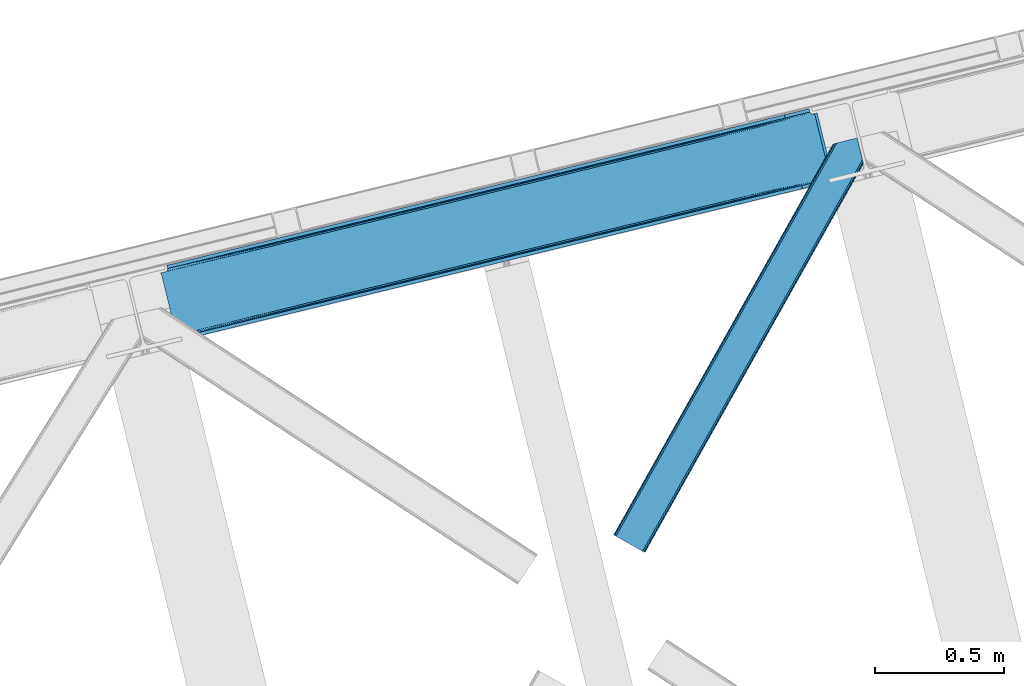
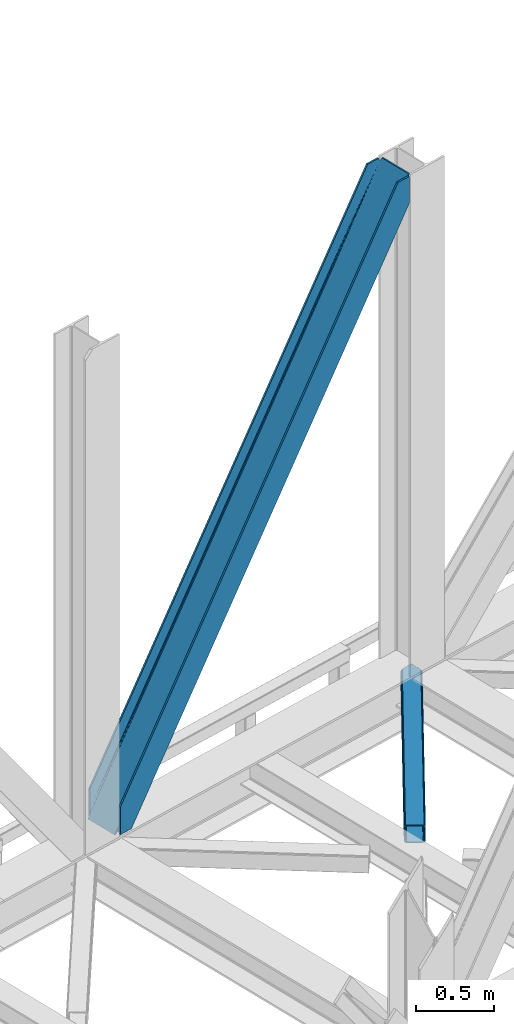
# One storey, part 77 of 93: 2 members.
"""IFC4 building model written with IfcOpenShell, lengths in millimetres."""

from ifc_helpers import new_model, entity, si_unit, converted_unit, derived_unit, direction, frame, origin, place, context, subcontext, project, spatial, triangles, type_object, element, save


model = new_model("IFC4")

# Units and contexts
model_context = context("Model", 3, precision=0.01, world=origin(), true_north=direction((6.12303176911189e-17, 1.0)))
plan_context = context("Plan", 3, precision=0.01, world=origin(), true_north=direction((6.12303176911189e-17, 1.0)))
body_context = subcontext(model_context, "Body", "Model", "MODEL_VIEW")
ifc_project = project(units=[si_unit("LENGTHUNIT", "METRE", prefix="MILLI"), si_unit("AREAUNIT", "SQUARE_METRE"), si_unit("VOLUMEUNIT", "CUBIC_METRE"), converted_unit("PLANEANGLEUNIT", "DEGREE", entity("IfcRatioMeasure", 0.0174532925199433), si_unit("PLANEANGLEUNIT", "RADIAN"), dimensions=[0, 0, 0, 0, 0, 0, 0]), si_unit("MASSUNIT", "GRAM", prefix="KILO"), derived_unit("MASSDENSITYUNIT", [(si_unit("MASSUNIT", "GRAM", prefix="KILO"), 1), (si_unit("LENGTHUNIT", "METRE"), -3)]), derived_unit("MOMENTOFINERTIAUNIT", [(si_unit("LENGTHUNIT", "METRE"), 4)]), si_unit("TIMEUNIT", "SECOND"), si_unit("FREQUENCYUNIT", "HERTZ"), si_unit("THERMODYNAMICTEMPERATUREUNIT", "DEGREE_CELSIUS"), derived_unit("THERMALTRANSMITTANCEUNIT", [(si_unit("MASSUNIT", "GRAM", prefix="KILO"), 1), (si_unit("THERMODYNAMICTEMPERATUREUNIT", "KELVIN"), -1), (si_unit("TIMEUNIT", "SECOND"), -3)]), derived_unit("VOLUMETRICFLOWRATEUNIT", [(si_unit("LENGTHUNIT", "METRE"), 3), (si_unit("TIMEUNIT", "SECOND"), -1)]), derived_unit("MASSFLOWRATEUNIT", [(si_unit("MASSUNIT", "GRAM", prefix="KILO"), 1), (si_unit("TIMEUNIT", "SECOND"), -1)]), derived_unit("ROTATIONALFREQUENCYUNIT", [(si_unit("TIMEUNIT", "SECOND"), -1)]), si_unit("ELECTRICCURRENTUNIT", "AMPERE"), si_unit("ELECTRICVOLTAGEUNIT", "VOLT"), si_unit("POWERUNIT", "WATT"), si_unit("FORCEUNIT", "NEWTON", prefix="KILO"), si_unit("ILLUMINANCEUNIT", "LUX"), si_unit("LUMINOUSFLUXUNIT", "LUMEN"), si_unit("LUMINOUSINTENSITYUNIT", "CANDELA"), derived_unit("USERDEFINED", [(si_unit("MASSUNIT", "GRAM", prefix="KILO"), -1), (si_unit("LENGTHUNIT", "METRE"), -2), (si_unit("TIMEUNIT", "SECOND"), 3), (si_unit("LUMINOUSFLUXUNIT", "LUMEN"), 1)]), derived_unit("LINEARVELOCITYUNIT", [(si_unit("LENGTHUNIT", "METRE"), 1), (si_unit("TIMEUNIT", "SECOND"), -1)]), si_unit("PRESSUREUNIT", "PASCAL"), derived_unit("USERDEFINED", [(si_unit("LENGTHUNIT", "METRE"), -2), (si_unit("MASSUNIT", "GRAM", prefix="KILO"), 1), (si_unit("TIMEUNIT", "SECOND"), -2)]), derived_unit("LINEARFORCEUNIT", [(si_unit("MASSUNIT", "GRAM", prefix="KILO"), 1), (si_unit("LENGTHUNIT", "METRE"), 1), (si_unit("TIMEUNIT", "SECOND"), -2), (si_unit("LENGTHUNIT", "METRE"), -1)]), derived_unit("PLANARFORCEUNIT", [(si_unit("MASSUNIT", "GRAM", prefix="KILO"), 1), (si_unit("LENGTHUNIT", "METRE"), 1), (si_unit("TIMEUNIT", "SECOND"), -2), (si_unit("LENGTHUNIT", "METRE"), -2)])], contexts=[model_context, plan_context])

# Site, building, storey
site_placement = place(None, origin())
site = spatial("IfcSite", under=ifc_project, at=site_placement, CompositionType="ELEMENT")
building_placement = place(site_placement, origin())
building = spatial("IfcBuilding", under=site, at=building_placement, CompositionType="ELEMENT")
storey_placement = place(building_placement, frame((0.0, 0.0, 15900.0)))
storey = spatial("IfcBuildingStorey", under=building, at=storey_placement, CompositionType="ELEMENT", Elevation=15900.0)

# Members
member_type_1 = type_object("IfcMemberType", PredefinedType="BRACE")
member_1_placement = place(storey_placement, frame((-11645.7647369385, 17824.6027038574, 3694.99929199219)))
element("IfcMember", 1, at=member_1_placement, inside=storey, type_object=member_type_1, ObjectType="Steel Vertical Brace", PredefinedType="BRACE", context=body_context, shape_type="Tessellation", body=[
    triangles([(2543.71740875244, 876.026760864261, 3910.2403930664), (2543.86100463867, 877.205758666994, 3909.96134033203), (2542.34249267578, 876.834851074222, 3911.00081176758), (2544.23714447021, 869.063232421875, 3911.00081176758), (2527.1870223999, 873.140890502931, 3906.29412231445), (2530.23276672363, 873.882705688477, 3911.00081176758), (2527.1870223999, 873.140890502931, 3884.1908203125), (2518.86892547608, 874.429183959961, 3898.31321411133), (2521.01472473145, 873.423431396484, 3899.16199951172), (2522.8994934082, 872.957180786136, 3877.06799926758), (2518.86892547608, 874.429183959961, 3868.81036376953), (2517.28820800781, 875.594229125978, 3898.850390625), (2517.28820800781, 875.594229125978, 3864.49202270508), (2515.87201538086, 877.455743408205, 3857.29478759765), (2515.70574645996, 877.331332397462, 3901.61533813476), (2513.89597320557, 881.222955322268, 3911.00081176758), (2514.70987701416, 878.98239440918, 3851.39514770508), (2514.17793273926, 880.262548828126, 3838.64708862305), (2514.70987701416, 878.98239440918, 3906.82664794922), (2514.37326965332, 879.734674072268, 3911.00081176758), (2514.17793273926, 880.262548828126, 3698.36960449219), (2513.89597320557, 881.222955322268, 3698.30216674805), (2522.8994934082, 872.957180786136, 3900.77120361328), (1281.82757263184, 579.864605712894, 1933.79126586914), (121.508862304689, 297.023730468751, 0.0), (1706.06330566406, 683.275735473635, 2589.5349609375), (2130.29787597656, 786.688027954104, 3245.28098144531), (857.58835144043, 476.451150512698, 1278.04757080078), (30.7527740478527, 274.901824951172, 0.0), (433.353781127931, 373.040020751956, 622.301550292967), (2511.05370483398, 892.881546020508, 3698.30216674805), (118.429980468751, 309.654354858401, 0.0), (2511.05370483398, 892.881546020508, 3911.00081176758), (2415.21013641357, 869.519018554689, 3911.00081176758), (23.883425903321, 286.608087158205, 214.700848388671), (23.883425903321, 286.608087158205, 0.0), (26.9576568603516, 273.658877563477, 0.0), (26.7251129150391, 274.948333740234, 0.0), (26.7251129150391, 274.948333740234, 214.700848388671), (2509.04452514648, 879.011462402344, 3911.00081176758), (2418.28901824951, 856.888394165042, 3911.00081176758), (26.9169616699219, 273.965835571289, 214.633410644528), (1250.04927978516, 572.117404174805, 1964.95680541992), (1676.92671203613, 676.173843383789, 2624.78862304687), (2103.8058883667, 780.230282592776, 3284.61811523437), (823.166033935548, 468.060964965822, 1305.12731323242), (26.9169616699219, 273.965835571289, 74.3536010742173), (396.287438964844, 364.004525756838, 645.295495605467), (25.435656738282, 266.62907409668, 14.6874755859353), (23.9973724365245, 264.751281738281, 13.8410156249993), (22.5346710205085, 263.467639160157, 35.9326904296868), (25.435656738282, 266.62907409668, 44.192651367186), (26.2995574951183, 268.389431762698, 14.1502990722656), (26.0007385253921, 268.181304931641, 48.2249633789033), (26.9088226318363, 270.661386108401, 54.6571289062485), (26.9088226318363, 270.661386108401, 11.3853515624978), (27.0332336425781, 272.584524536134, 61.6055419921868), (27.0332336425781, 272.584524536134, 6.17404174804688), (22.5346710205085, 263.467639160157, 12.2294860839829), (18.6395599365242, 261.656121826174, 28.8121948242188), (18.6395599365242, 261.656121826174, 6.70889282226563), (0.0, 257.112213134766, 0.0), (14.3014526367188, 260.598046875002, 0.0), (412.366690063478, 356.486380004884, 636.079779052732), (0.597637939454216, 256.057626342776, 0.0), (4.08579711914172, 249.874282836914, 0.0), (2122.62276306152, 766.289273071292, 3274.64197998047), (2534.31914520264, 866.644775390625, 3911.00081176758), (2530.82982330322, 872.828118896487, 3911.00081176758), (2119.88455810547, 772.712136840823, 3275.40239868164), (2109.70145874024, 780.257025146486, 3280.80206909179), (2115.34762573242, 777.616488647462, 3277.56505737305), (407.82975769043, 361.391894531251, 638.242437744138), (402.183590698243, 364.031268310548, 641.479449462888), (415.109545898438, 350.064678955081, 635.319360351561), (829.062185668947, 468.087707519531, 1301.30894165039), (1255.93961791992, 572.142984008791, 1961.14075927734), (1682.81821289063, 676.199423217775, 2620.97025146484), (834.707189941408, 465.447171020511, 1298.07192993164), (1261.58578491211, 569.503610229494, 1957.90374755859), (1688.46903076172, 673.561212158205, 2617.73323974609), (839.24877319336, 460.543981933595, 1295.90927124023), (1266.12736816406, 564.600421142579, 1955.74108886719), (1693.00596313477, 668.656860351563, 2615.57058105469), (841.988140869142, 454.121118164065, 1295.15117797851), (1268.86557312012, 558.177557373048, 1954.98067016601), (1695.74416809082, 662.233996582032, 2614.81248779297), (428.11107788086, 370.350650024415, 626.119921874997), (424.31247253418, 365.409091186524, 629.35693359375), (2119.48225708008, 772.614468383792, 3254.49669799805), (2121.25307922363, 779.057098388672, 3252.33403930664), (423.061386108398, 352.004095458986, 632.280010986327), (14.0096099853527, 252.292739868164, 0.0), (14.2619201660164, 259.388818359377, 0.0), (422.53699951172, 358.966461181641, 631.519592285156), (2125.05110321045, 783.998657226563, 3249.09702758789), (846.772732543946, 462.377590942386, 1287.26328735351), (847.297119140625, 455.415225219727, 1288.02370605469), (1271.00730285645, 565.789883422854, 1943.00930786133), (1271.53168945313, 558.827517700196, 1943.76740112304), (1695.24303588867, 669.201013183596, 2598.75300292969), (1695.76742248535, 662.238647460938, 2599.5110961914), (2120.00199279785, 765.650939941406, 3255.25711669922), (848.548205566407, 468.821383666993, 1285.10062866211), (1272.78277587891, 572.232513427734, 1940.84664916992), (1697.01850891113, 675.644805908203, 2596.59034423828), (852.345648193361, 473.762942504884, 1281.86361694336), (1276.58138122559, 577.175234985352, 1937.60963745117), (1700.81595153809, 680.586364746094, 2593.35333251953), (2589.49949798584, 640.273709106448, 3911.00081176758), (2177.80311584473, 539.918206787112, 3274.64197998047), (1324.04592590332, 331.805328369141, 1954.98067016601), (1750.92452087402, 435.861767578128, 2614.81248779297), (897.168493652345, 227.750051879884, 1295.15117797851), (470.289898681642, 123.693612670901, 635.319360351561), (59.2673126220707, 23.50205383301, 0.0), (2599.41749725342, 642.691003417971, 3911.00081176758), (2175.18234558106, 539.278710937502, 3255.25711669922), (1750.94777526856, 435.867581176761, 2599.5110961914), (1326.71204223633, 332.455288696292, 1943.76740112304), (902.477471923828, 229.044158935547, 1288.02370605469), (478.241738891602, 125.631866455078, 632.280010986327), (69.1899627685561, 25.9216735839873, 0.0), (59.015002441407, 16.4071380615242, 0.0), (72.6781219482436, 19.7383300781257, 0.0), (58.9696563720718, 15.1955841064482, 0.0), (73.2711090087905, 18.6825805664084, 0.0), (77.6092163085941, 19.739492797853, 6.70889282226563), (77.6092163085941, 19.739492797853, 28.8121948242188), (2589.24718780518, 633.177630615235, 3911.00081176758), (2601.31214904785, 634.918222045901, 3911.00081176758), (2589.2024230957, 631.967239379883, 3911.00081176758), (2602.83066101074, 635.289129638673, 3909.96134033203), (2602.16035308838, 636.269302368164, 3910.2403930664), (2586.15667877197, 631.22426147461, 3906.29412231445), (2586.15667877197, 631.22426147461, 3884.1908203125), (2572.75110168457, 617.663461303713, 3911.00081176758), (2577.81474609375, 619.473815917969, 3911.00081176758), (2577.76765594482, 620.297021484377, 3906.82664794922), (2172.75865631104, 521.571652221683, 3280.80206909179), (2577.89206695557, 622.220159912111, 3901.61533813476), (2578.49726257324, 624.490951538086, 3898.850390625), (2582.2662185669, 629.413906860354, 3900.77120361328), (2178.32750244141, 532.955841064453, 3275.40239868164), (2580.80293579102, 628.130264282227, 3899.15967407226), (2579.36465148926, 626.252471923828, 3898.31321411133), (2176.55668029785, 526.513211059573, 3277.56505737305), (470.809634399415, 116.730084228519, 636.079779052732), (469.03881225586, 110.288616943362, 638.242437744138), (81.900814819337, 19.9232025146484, 35.9326904296868), (85.9319641113289, 18.4523620605469, 44.192651367186), (87.5086120605483, 17.2861541748061, 48.5109924316384), (2167.51188354492, 518.882281494141, 3284.61811523437), (459.994015502931, 102.656524658203, 645.295495605467), (465.24020690918, 105.345895385744, 641.479449462888), (90.6235382080085, 12.618997192385, 74.3536010742173), (90.0910125732426, 13.899151611331, 61.6055419921868), (88.9282928466801, 15.4258026123061, 55.7059020996094), (897.692880249024, 220.787686157229, 1295.90927124023), (1324.5703125, 324.844125366213, 1955.74108886719), (1751.4489074707, 428.899401855469, 2615.57058105469), (895.916244506836, 214.343893432619, 1298.07192993164), (1322.79483947754, 318.400332641602, 1957.90374755859), (1749.67808532715, 422.457934570313, 2617.73323974609), (892.118801879884, 209.402334594728, 1301.30894165039), (1318.99739685059, 313.458773803712, 1961.14075927734), (1745.87599182129, 417.514050292972, 2620.97025146484), (886.872610473634, 206.71296386719, 1305.12731323242), (1313.75469360352, 310.770565795901, 1964.95680541992), (1740.63328857422, 414.827005004885, 2624.78862304687), (90.6235382080085, 12.618997192385, 214.633410644528), (2481.9955947876, 595.541555786134, 3911.00081176758), (491.167694091797, 111.666439819339, 626.119921874997), (89.0945617675789, 15.5502136230498, 11.3853515624978), (87.5086120605483, 17.2861541748061, 14.1502990722656), (90.0910125732426, 13.899151611331, 6.17404174804688), (480.981106567384, 119.210165405275, 631.519592285156), (83.7855834960938, 19.4581146240234, 13.8386901855447), (81.900814819337, 19.9232025146484, 12.2294860839829), (85.9319641113289, 18.4523620605469, 14.6874755859353), (485.52152709961, 114.305813598636, 629.35693359375), (2182.46213378906, 527.953820800783, 3252.33403930664), (2582.2662185669, 629.413906860354, 3877.06799926758), (2579.36465148926, 626.252471923828, 3868.81036376953), (2177.92520141602, 532.858172607423, 3254.49669799805), (2578.79608154297, 624.697915649416, 3864.77572631836), (2577.89206695557, 622.220159912111, 3858.34588623047), (2188.10830078125, 525.313284301759, 3249.09702758789), (2577.76765594482, 620.297021484377, 3851.39514770508), (94.4593505859375, 13.5538238525405, 0.0), (90.5188934326179, 12.9108398437529, 0.0), (497.059194946291, 111.692019653321, 622.301550292967), (2577.88392791748, 618.914547729495, 3838.64708862305), (2194.00445251465, 525.340026855469, 3245.28098144531), (915.403427124023, 215.07756958008, 1281.86361694336), (921.294927978517, 215.10431213379, 1278.04757080078), (1339.63799743652, 318.489862060549, 1937.60963745117), (1345.53414916992, 318.516604614259, 1933.79126586914), (1763.87373046875, 421.900991821291, 2593.35333251953), (1769.76871948242, 421.928897094727, 2589.5349609375), (909.757260131837, 217.718106079104, 1285.10062866211), (1333.99183044434, 321.129235839846, 1940.84664916992), (1758.22756347656, 424.541528320315, 2596.59034423828), (905.215676879883, 222.621295166016, 1287.26328735351), (1329.45024719238, 326.033587646485, 1943.00930786133), (1753.68598022461, 429.444717407227, 2598.75300292969), (90.9049163818363, 11.6585906982436, 0.0), (90.9049163818363, 11.6585906982436, 214.700848388671), (2485.07389526367, 582.910931396487, 3911.00081176758), (93.7466033935561, 0.0, 214.700848388671), (93.7466033935561, 0.0, 0.0), (188.293157958986, 23.046267700196, 0.0), (185.214276123048, 35.6768920898467, 0.0), (2577.88392791748, 618.914547729495, 3698.36960449219), (2578.07577667236, 617.93204956055, 3911.00081176758), (2578.07577667236, 617.93204956055, 3698.30216674805), (2580.91746368408, 606.273458862306, 3698.30216674805), (2580.91746368408, 606.273458862306, 3911.00081176758)], [[1, 2, 3], [3, 4, 1], [3, 5, 6], [5, 3, 2], [7, 5, 2], [8, 9, 10], [10, 11, 8], [8, 11, 12], [13, 12, 11], [14, 15, 12], [16, 17, 18], [19, 15, 14], [16, 20, 19], [19, 17, 16], [14, 17, 19], [18, 21, 22], [22, 16, 18], [13, 14, 12], [9, 23, 10], [5, 7, 23], [10, 23, 7], [21, 24, 25], [26, 21, 27], [21, 26, 24], [21, 18, 27], [28, 25, 24], [29, 25, 30], [28, 30, 25], [31, 22, 32], [22, 21, 25], [25, 32, 22], [16, 22, 33], [31, 33, 22], [34, 31, 35], [31, 34, 33], [32, 35, 31], [36, 35, 32], [32, 29, 36], [29, 32, 25], [37, 38, 29], [38, 36, 29], [38, 39, 35], [35, 36, 38], [16, 33, 40], [20, 16, 40], [34, 40, 33], [34, 41, 40], [39, 34, 35], [41, 39, 42], [39, 41, 34], [41, 42, 43], [43, 44, 41], [44, 45, 41], [40, 41, 45], [46, 43, 42], [42, 47, 48], [48, 46, 42], [49, 50, 51], [51, 52, 49], [53, 49, 52], [52, 54, 53], [55, 56, 53], [57, 58, 55], [56, 55, 58], [38, 37, 58], [58, 47, 38], [39, 38, 47], [47, 42, 39], [57, 47, 58], [54, 55, 53], [50, 59, 51], [51, 59, 60], [61, 60, 59], [60, 61, 62], [63, 62, 61], [64, 65, 66], [67, 68, 69], [70, 8, 12], [70, 69, 23], [23, 9, 70], [9, 8, 70], [69, 5, 23], [69, 6, 5], [71, 72, 12], [12, 15, 71], [19, 40, 45], [45, 71, 19], [73, 74, 57], [57, 55, 73], [64, 51, 60], [60, 65, 64], [60, 62, 65], [64, 73, 54], [54, 52, 64], [52, 51, 64], [55, 54, 73], [74, 48, 47], [47, 57, 74], [19, 20, 40], [15, 19, 71], [12, 72, 70], [69, 70, 67], [66, 75, 64], [76, 46, 48], [48, 74, 76], [77, 43, 46], [46, 76, 77], [78, 44, 43], [43, 77, 78], [71, 45, 78], [44, 78, 45], [79, 76, 73], [74, 73, 76], [80, 77, 79], [76, 79, 77], [81, 78, 80], [77, 80, 78], [72, 71, 78], [78, 81, 72], [82, 79, 64], [73, 64, 79], [83, 80, 79], [79, 82, 83], [84, 81, 80], [80, 83, 84], [70, 72, 81], [81, 84, 70], [85, 82, 64], [64, 75, 85], [86, 83, 82], [82, 85, 86], [87, 84, 86], [83, 86, 84], [67, 70, 87], [84, 87, 70], [88, 89, 53], [53, 56, 88], [30, 88, 58], [58, 29, 30], [90, 10, 7], [7, 1, 90], [7, 2, 1], [90, 91, 13], [13, 11, 90], [11, 10, 90], [92, 93, 94], [95, 49, 53], [95, 94, 61], [61, 59, 95], [59, 50, 95], [50, 49, 95], [94, 63, 61], [53, 89, 95], [94, 95, 92], [14, 91, 17], [14, 13, 91], [91, 96, 17], [18, 17, 96], [96, 27, 18], [58, 37, 29], [56, 58, 88], [97, 98, 92], [92, 95, 97], [99, 100, 98], [98, 97, 99], [101, 102, 100], [100, 99, 101], [90, 103, 102], [102, 101, 90], [1, 4, 90], [103, 90, 4], [104, 97, 95], [95, 89, 104], [105, 99, 104], [97, 104, 99], [106, 101, 105], [99, 105, 101], [91, 90, 101], [101, 106, 91], [107, 104, 88], [89, 88, 104], [108, 105, 107], [104, 107, 105], [109, 106, 105], [105, 108, 109], [96, 91, 106], [106, 109, 96], [28, 107, 88], [88, 30, 28], [24, 108, 107], [107, 28, 24], [26, 109, 24], [108, 24, 109], [27, 96, 26], [109, 26, 96], [110, 68, 67], [87, 111, 67], [112, 113, 87], [112, 87, 86], [67, 111, 110], [87, 113, 111], [85, 114, 112], [112, 86, 85], [85, 75, 115], [66, 116, 75], [85, 115, 114], [75, 116, 115], [4, 117, 118], [119, 103, 118], [100, 102, 119], [100, 119, 120], [118, 103, 4], [119, 102, 103], [98, 100, 120], [120, 121, 98], [121, 122, 92], [123, 93, 122], [121, 92, 98], [122, 93, 92], [66, 116, 93], [116, 124, 125], [124, 126, 125], [62, 65, 63], [65, 66, 94], [93, 116, 123], [127, 125, 126], [125, 123, 116], [93, 94, 66], [94, 63, 65], [128, 129, 126], [126, 127, 128], [110, 130, 131], [130, 132, 131], [6, 69, 3], [3, 69, 68], [110, 117, 68], [68, 117, 4], [110, 131, 117], [4, 3, 68], [133, 134, 131], [117, 131, 134], [131, 135, 133], [131, 132, 135], [135, 136, 133], [137, 138, 139], [140, 141, 142], [140, 139, 141], [130, 143, 135], [144, 145, 143], [144, 146, 145], [143, 130, 144], [135, 132, 130], [144, 147, 142], [142, 146, 144], [111, 144, 130], [148, 115, 116], [149, 150, 151], [148, 124, 129], [129, 149, 148], [129, 150, 149], [124, 126, 129], [151, 152, 149], [116, 124, 148], [130, 110, 111], [142, 147, 140], [137, 139, 153], [140, 153, 139], [154, 155, 156], [157, 156, 155], [157, 149, 158], [157, 155, 149], [152, 158, 149], [159, 114, 148], [115, 148, 114], [160, 112, 159], [114, 159, 112], [161, 113, 112], [112, 160, 161], [144, 111, 113], [113, 161, 144], [162, 159, 148], [148, 149, 162], [163, 160, 162], [159, 162, 160], [164, 161, 163], [160, 163, 161], [147, 144, 164], [161, 164, 144], [165, 162, 149], [149, 155, 165], [166, 163, 162], [162, 165, 166], [167, 164, 163], [163, 166, 167], [140, 147, 167], [164, 167, 147], [168, 165, 154], [155, 154, 165], [169, 166, 168], [165, 168, 166], [170, 167, 169], [166, 169, 167], [153, 140, 167], [167, 170, 153], [169, 171, 172], [172, 153, 170], [153, 172, 137], [170, 169, 172], [171, 169, 168], [168, 154, 171], [156, 171, 154], [173, 174, 175], [173, 176, 174], [177, 178, 179], [177, 180, 178], [179, 128, 177], [128, 125, 177], [128, 127, 125], [177, 181, 175], [175, 180, 177], [122, 177, 125], [182, 183, 184], [185, 134, 136], [136, 182, 185], [136, 183, 182], [134, 133, 136], [184, 186, 182], [182, 186, 187], [187, 188, 182], [187, 189, 188], [190, 191, 176], [173, 192, 176], [190, 176, 192], [189, 193, 188], [194, 188, 193], [125, 123, 122], [175, 181, 173], [195, 196, 173], [192, 173, 196], [197, 198, 195], [196, 195, 198], [199, 200, 198], [198, 197, 199], [188, 194, 200], [200, 199, 188], [201, 195, 173], [173, 181, 201], [202, 197, 195], [195, 201, 202], [203, 199, 197], [197, 202, 203], [182, 188, 199], [199, 203, 182], [204, 201, 177], [181, 177, 201], [205, 202, 201], [201, 204, 205], [206, 203, 205], [202, 205, 203], [185, 182, 206], [203, 206, 182], [121, 204, 122], [177, 122, 204], [120, 205, 121], [204, 121, 205], [119, 206, 205], [205, 120, 119], [118, 185, 206], [206, 119, 118], [117, 134, 185], [185, 118, 117], [180, 151, 150], [150, 179, 178], [175, 158, 152], [175, 152, 151], [151, 180, 175], [207, 157, 176], [176, 157, 158], [158, 174, 176], [207, 208, 156], [171, 156, 208], [156, 157, 207], [176, 191, 207], [175, 174, 158], [150, 178, 180], [179, 150, 129], [129, 128, 179], [208, 172, 171], [209, 208, 210], [208, 209, 172], [211, 210, 207], [208, 207, 210], [212, 190, 211], [190, 212, 213], [191, 207, 190], [207, 211, 190], [198, 214, 213], [194, 214, 200], [194, 193, 214], [198, 200, 214], [213, 196, 198], [192, 196, 213], [213, 190, 192], [146, 184, 183], [183, 143, 145], [142, 186, 184], [142, 187, 186], [184, 146, 142], [215, 189, 139], [187, 141, 139], [139, 189, 187], [214, 193, 216], [215, 216, 193], [193, 189, 215], [139, 138, 215], [142, 141, 187], [183, 145, 146], [136, 135, 143], [143, 183, 136], [217, 209, 210], [217, 218, 209], [210, 212, 217], [211, 212, 210], [215, 138, 137], [218, 215, 137], [137, 209, 218], [209, 137, 172], [214, 216, 213], [216, 217, 212], [212, 213, 216], [218, 217, 216], [216, 215, 218]]),
])
member_type_2 = type_object("IfcMemberType", PredefinedType="BRACE")
member_2_placement = place(storey_placement, frame((-9892.01829528809, 16998.9926330566, 3510.00011901855)))
element("IfcMember", 2, at=member_2_placement, inside=storey, type_object=member_type_2, ObjectType="Steel Horizontal Brace", PredefinedType="BRACE", context=body_context, shape_type="Tessellation", body=[
    triangles([(963.930697631835, 1521.10947875976, 138.667117309571), (961.605839538573, 1530.64726867676, 139.999594116212), (106.810922241211, 8.56924438476563, 139.999594116212), (112.650100708008, 5.29037475585938, 138.667117309571), (965.901507568358, 1513.02508850098, 134.874325561526), (117.598635864257, 2.50914916992042, 134.874325561526), (967.21828765869, 1507.62192993164, 129.197927856447), (120.908898925782, 0.65228576660229, 129.197927856447), (967.680468749999, 1505.72553405762, 122.500662231447), (122.068130493164, 0.0, 122.500662231447), (967.680468749999, 1505.72553405762, 17.5000946044929), (122.068130493164, 0.0, 17.5000946044929), (15.2572082519528, 59.9835479736321, 139.999594116212), (873.405409240722, 1588.02516174316, 139.999594116212), (943.45694732666, 1605.10086364746, 139.999594116212), (851.919511413575, 1582.78827209473, 129.197927856447), (850.152758789061, 1582.35690307617, 122.500662231447), (1.16388244628797, 67.9005065917954, 129.197927856447), (0.0, 68.5527923583977, 122.500662231447), (856.962226867676, 1584.0172668457, 134.874325561526), (4.46949462890552, 66.04248046875, 134.874325561526), (864.503627014159, 1585.8555267334, 138.667117309571), (9.4215179443363, 63.2635803222656, 138.667117309571), (850.152758789061, 1582.35690307617, 17.5000946044929), (0.0, 68.5527923583977, 17.5000946044929), (1.16388244628797, 67.9005065917954, 10.8028289794929), (809.934864807128, 1506.81616516113, 9.52034912109593), (809.674415588379, 1505.78367004394, 9.02037963867406), (4.46949462890552, 66.04248046875, 5.12526855468968), (809.409315490722, 1504.7488494873, 8.52041015625218), (810.327864074707, 1500.98047485352, 5.12526855468968), (852.276466369629, 1582.87431335449, 10.8679412841811), (852.710160827637, 1582.98012084961, 9.52034912109593), (812.29867401123, 1492.89608459473, 1.33247680664135), (814.623532104491, 1483.35829467774, 0.0), (9.4215179443363, 63.2635803222656, 1.33247680664135), (15.2572082519528, 59.9835479736321, 0.0), (842.022441101073, 1370.95817871094, 0.0), (106.810922241211, 8.56924438476563, 0.0), (876.670907592774, 1379.40417480469, 0.0), (814.517724609375, 1484.6570526123, 8.82736816406396), (814.736315917968, 1482.89553222656, 8.42274169922166), (814.460751342773, 1485.77442626953, 9.13665161133031), (814.401452636719, 1486.88249816895, 9.44360961914208), (814.630508422852, 1487.55222473144, 9.52034912109593), (870.68522644043, 1587.36241149902, 9.52034912109593), (817.053616333007, 1473.39029846191, 6.99957275390625), (842.022441101073, 1370.95817871094, 6.99957275390625), (15.5234710693348, 59.8347198486335, 8.3320495605476), (21.3638122558586, 56.5558502197273, 6.99957275390625), (866.261659240723, 1586.28340759277, 12.1260040283232), (10.5714477539059, 62.6147827148452, 12.1260040283232), (861.223013305664, 1585.05557556152, 17.8035644531265), (859.452191162109, 1584.62420654297, 24.4996673583992), (7.26467285156286, 64.4728088378906, 17.8035644531265), (6.1054412841786, 65.1250946044929, 24.4996673583992), (100.704318237304, 11.9957794189468, 6.99957275390625), (867.366824340819, 1377.13687133789, 6.99957275390625), (885.567457580566, 1381.57380981445, 1.33247680664135), (879.391090393066, 1380.06808776856, 9.52034912109593), (893.113508605957, 1383.41323242187, 5.12526855468968), (876.06978149414, 1379.25767211914, 8.82504272460938), (897.365574645995, 1384.44921569824, 9.52034912109593), (963.083074951172, 1500.72467651367, 10.8702667236357), (120.908898925782, 0.65228576660229, 10.8028289794929), (117.598635864257, 2.50914916992042, 5.12526855468968), (967.671166992188, 1505.76390380859, 16.5199218750022), (961.988374328614, 1499.52126159668, 9.52034912109593), (112.650100708008, 5.29037475585938, 1.33247680664135), (960.31696472168, 1517.3771484375, 12.1260040283232), (964.582402038573, 1518.43522338867, 16.5199218750022), (957.29273071289, 1518.78520202637, 9.52034912109593), (114.803457641601, 4.07998352050708, 17.8035644531265), (115.967340087891, 3.42769775390479, 24.4996673583992), (965.250965881347, 1515.69353027344, 24.4996673583992), (964.69518585205, 1517.9724609375, 17.8686767578147), (111.496682739258, 5.93800964355614, 12.1260040283232), (106.544659423827, 8.71690979004052, 8.3320495605476), (965.250965881347, 1515.69353027344, 115.501089477541), (115.967340087891, 3.42769775390479, 115.501089477541), (964.788203430175, 1517.59108886719, 122.196029663086), (963.471423339843, 1522.9930847168, 127.87475280762), (961.500613403319, 1531.07863769531, 131.667544555665), (959.175755310058, 1540.61526489258, 133.000021362306), (943.45694732666, 1605.10086364746, 133.000021362306), (114.803457641601, 4.07998352050708, 122.196029663086), (111.496682739258, 5.93800964355614, 127.87475280762), (106.544659423827, 8.71690979004052, 131.667544555665), (100.704318237304, 11.9957794189468, 133.000021362306), (10.5714477539059, 62.6147827148452, 127.87475280762), (21.3638122558586, 56.5558502197273, 133.000021362306), (15.5234710693348, 59.8347198486335, 131.667544555665), (6.1054412841786, 65.1250946044929, 115.501089477541), (7.26467285156286, 64.4728088378906, 122.196029663086), (861.223013305664, 1585.05557556152, 122.196029663086), (873.807710266114, 1588.12283020019, 131.667544555665), (882.70484161377, 1590.29246520996, 133.000021362306), (866.261659240723, 1586.28340759277, 127.87475280762), (859.452191162109, 1584.62420654297, 115.501089477541)], [[1, 2, 3], [3, 4, 1], [5, 1, 4], [4, 6, 5], [7, 5, 6], [6, 8, 7], [9, 7, 8], [8, 10, 9], [11, 9, 10], [10, 12, 11], [13, 2, 14], [13, 3, 2], [2, 15, 14], [16, 17, 18], [19, 18, 17], [20, 16, 21], [18, 21, 16], [22, 20, 23], [21, 23, 20], [14, 22, 13], [23, 13, 22], [17, 24, 25], [25, 19, 17], [26, 25, 24], [27, 28, 29], [30, 29, 28], [30, 31, 29], [26, 32, 27], [27, 29, 26], [32, 33, 27], [34, 35, 36], [37, 36, 35], [31, 34, 29], [36, 29, 34], [24, 32, 26], [38, 37, 35], [39, 38, 40], [38, 39, 37], [41, 42, 30], [43, 41, 30], [44, 43, 28], [45, 27, 46], [33, 46, 27], [34, 42, 35], [30, 42, 31], [31, 42, 34], [47, 35, 42], [47, 38, 35], [38, 47, 48], [49, 50, 47], [44, 51, 52], [44, 46, 51], [52, 49, 42], [43, 52, 41], [43, 44, 52], [52, 42, 41], [47, 42, 49], [53, 54, 55], [56, 55, 54], [51, 53, 52], [55, 52, 53], [48, 57, 58], [50, 48, 47], [48, 50, 57], [59, 60, 61], [58, 38, 48], [58, 62, 40], [58, 40, 38], [40, 60, 59], [61, 60, 63], [62, 60, 40], [64, 65, 63], [65, 66, 61], [61, 63, 65], [12, 65, 64], [64, 11, 12], [64, 67, 11], [63, 68, 64], [59, 61, 66], [66, 69, 59], [40, 59, 69], [69, 39, 40], [70, 67, 64], [70, 71, 67], [64, 72, 70], [68, 72, 64], [63, 60, 68], [72, 68, 60], [73, 74, 75], [73, 71, 70], [73, 76, 71], [77, 70, 60], [60, 78, 77], [60, 62, 78], [70, 72, 60], [78, 62, 58], [58, 57, 78], [70, 77, 73], [75, 76, 73], [79, 75, 74], [74, 80, 79], [76, 67, 71], [9, 11, 75], [11, 76, 75], [75, 79, 9], [11, 67, 76], [81, 9, 79], [7, 9, 81], [5, 81, 82], [81, 5, 7], [82, 1, 5], [83, 1, 82], [83, 84, 2], [83, 2, 1], [84, 15, 2], [84, 85, 15], [81, 79, 86], [80, 86, 79], [82, 81, 87], [86, 87, 81], [83, 82, 88], [87, 88, 82], [84, 83, 89], [88, 89, 83], [8, 87, 86], [80, 12, 10], [8, 86, 10], [8, 6, 87], [86, 80, 10], [87, 6, 4], [89, 3, 13], [3, 88, 4], [88, 3, 89], [88, 87, 4], [65, 77, 66], [74, 12, 80], [12, 73, 65], [73, 12, 74], [65, 73, 77], [39, 57, 37], [69, 66, 77], [77, 78, 69], [78, 57, 39], [39, 69, 78], [90, 23, 21], [13, 91, 89], [13, 92, 91], [92, 13, 23], [90, 92, 23], [93, 19, 25], [18, 94, 90], [21, 18, 90], [94, 18, 19], [93, 94, 19], [36, 52, 29], [37, 57, 50], [50, 49, 37], [49, 52, 36], [36, 37, 49], [26, 29, 52], [25, 56, 93], [55, 25, 26], [25, 55, 56], [55, 26, 52], [95, 17, 16], [96, 22, 14], [15, 97, 14], [97, 15, 85], [97, 96, 14], [98, 22, 96], [98, 95, 20], [20, 22, 98], [16, 20, 95], [54, 24, 17], [51, 33, 53], [95, 99, 17], [51, 46, 33], [54, 53, 24], [99, 54, 17], [32, 24, 53], [53, 33, 32], [91, 84, 89], [84, 91, 97], [85, 84, 97], [54, 99, 56], [93, 56, 99], [96, 97, 91], [91, 92, 96], [98, 96, 92], [92, 90, 98], [95, 98, 90], [90, 94, 95], [99, 95, 94], [94, 93, 99]]),
])

save(model, "model.ifc")
